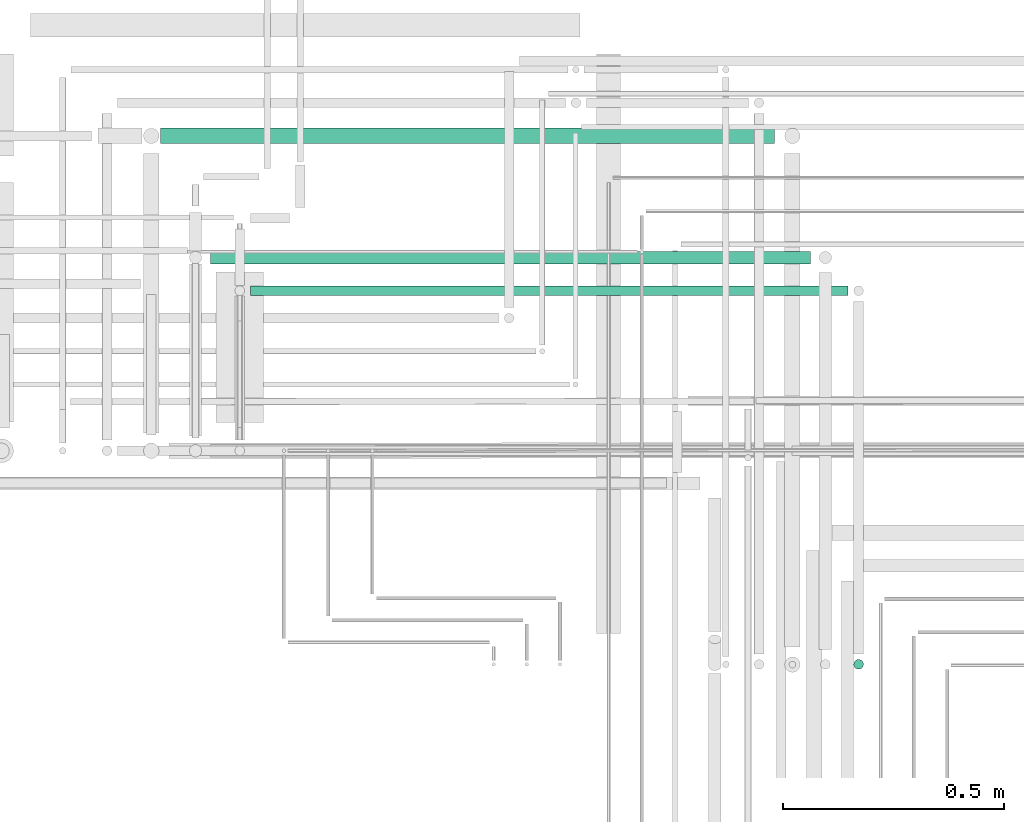
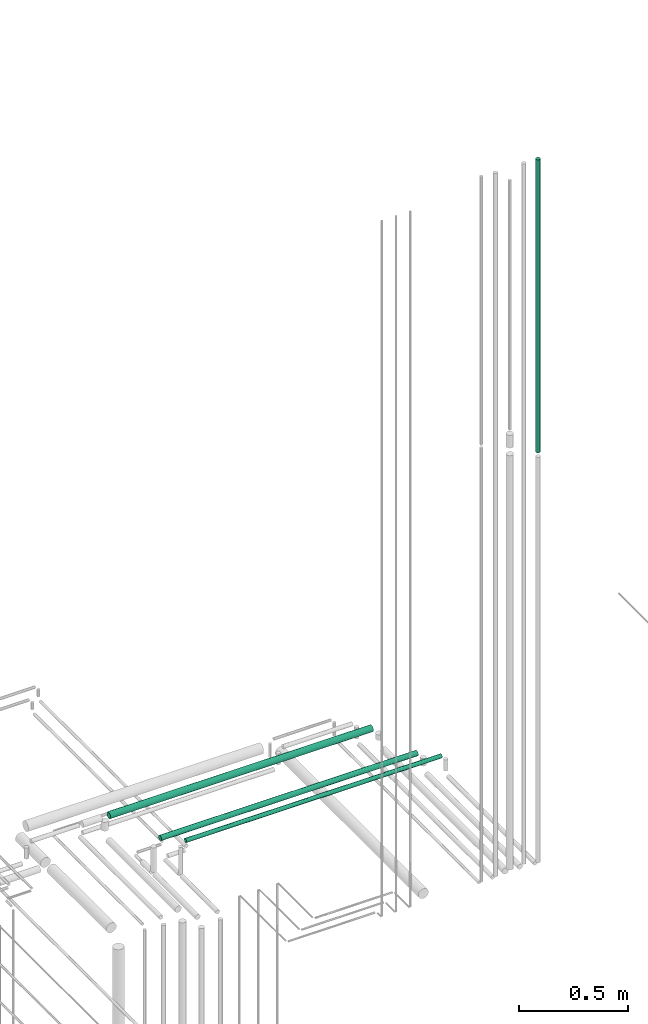
# One storey, part 96 of 331: 4 flow segments.
"""IFC2X3 building model written with IfcOpenShell, lengths in millimetres."""

from ifc_helpers import new_model, entity, si_unit, converted_unit, derived_unit, direction, frame, frame_2d, origin, origin_2d_with_axis, place, context, subcontext, project, spatial, circle, extrude, type_object, element, save


model = new_model("IFC2X3")

# Units and contexts
model_context = context("Model", 3, precision=0.01, world=origin(), true_north=direction((6.12303176911189e-17, 1.0)))
body_context = subcontext(model_context, "Body", "Model", "MODEL_VIEW")
ifc_project = project(units=[si_unit("LENGTHUNIT", "METRE", prefix="MILLI"), si_unit("AREAUNIT", "SQUARE_METRE"), si_unit("VOLUMEUNIT", "CUBIC_METRE"), converted_unit("PLANEANGLEUNIT", "DEGREE", entity("IfcRatioMeasure", 0.0174532925199433), si_unit("PLANEANGLEUNIT", "RADIAN"), dimensions=[0, 0, 0, 0, 0, 0, 0]), si_unit("MASSUNIT", "GRAM", prefix="KILO"), derived_unit("MASSDENSITYUNIT", [(si_unit("MASSUNIT", "GRAM", prefix="KILO"), 1), (si_unit("LENGTHUNIT", "METRE"), -3)]), derived_unit("MOMENTOFINERTIAUNIT", [(si_unit("LENGTHUNIT", "METRE"), 4)]), si_unit("TIMEUNIT", "SECOND"), si_unit("FREQUENCYUNIT", "HERTZ"), si_unit("THERMODYNAMICTEMPERATUREUNIT", "DEGREE_CELSIUS"), derived_unit("THERMALTRANSMITTANCEUNIT", [(si_unit("MASSUNIT", "GRAM", prefix="KILO"), 1), (si_unit("THERMODYNAMICTEMPERATUREUNIT", "KELVIN"), -1), (si_unit("TIMEUNIT", "SECOND"), -3)]), derived_unit("VOLUMETRICFLOWRATEUNIT", [(si_unit("LENGTHUNIT", "METRE"), 3), (si_unit("TIMEUNIT", "SECOND"), -1)]), derived_unit("MASSFLOWRATEUNIT", [(si_unit("MASSUNIT", "GRAM", prefix="KILO"), 1), (si_unit("TIMEUNIT", "SECOND"), -1)]), derived_unit("ROTATIONALFREQUENCYUNIT", [(si_unit("TIMEUNIT", "SECOND"), -1)]), si_unit("ELECTRICCURRENTUNIT", "AMPERE"), si_unit("ELECTRICVOLTAGEUNIT", "VOLT"), si_unit("POWERUNIT", "WATT"), si_unit("FORCEUNIT", "NEWTON", prefix="KILO"), si_unit("ILLUMINANCEUNIT", "LUX"), si_unit("LUMINOUSFLUXUNIT", "LUMEN"), si_unit("LUMINOUSINTENSITYUNIT", "CANDELA"), derived_unit("USERDEFINED", [(si_unit("MASSUNIT", "GRAM", prefix="KILO"), -1), (si_unit("LENGTHUNIT", "METRE"), -2), (si_unit("TIMEUNIT", "SECOND"), 3), (si_unit("LUMINOUSFLUXUNIT", "LUMEN"), 1)]), derived_unit("LINEARVELOCITYUNIT", [(si_unit("LENGTHUNIT", "METRE"), 1), (si_unit("TIMEUNIT", "SECOND"), -1)]), si_unit("PRESSUREUNIT", "PASCAL"), derived_unit("USERDEFINED", [(si_unit("LENGTHUNIT", "METRE"), -2), (si_unit("MASSUNIT", "GRAM", prefix="KILO"), 1), (si_unit("TIMEUNIT", "SECOND"), -2)]), derived_unit("LINEARFORCEUNIT", [(si_unit("MASSUNIT", "GRAM", prefix="KILO"), 1), (si_unit("LENGTHUNIT", "METRE"), 1), (si_unit("TIMEUNIT", "SECOND"), -2), (si_unit("LENGTHUNIT", "METRE"), -1)]), derived_unit("PLANARFORCEUNIT", [(si_unit("MASSUNIT", "GRAM", prefix="KILO"), 1), (si_unit("LENGTHUNIT", "METRE"), 1), (si_unit("TIMEUNIT", "SECOND"), -2), (si_unit("LENGTHUNIT", "METRE"), -2)])], contexts=[model_context])

# Site, building, storey
site_placement = place(None, frame((0.0, -0.00077364408347762, 0.0)))
site = spatial("IfcSite", under=ifc_project, at=site_placement, CompositionType="ELEMENT")
building_placement = place(site_placement, origin())
building = spatial("IfcBuilding", under=site, at=building_placement, CompositionType="ELEMENT")
storey_placement = place(building_placement, origin())
storey = spatial("IfcBuildingStorey", under=building, at=storey_placement, CompositionType="ELEMENT", Elevation=0.0)

# Flow segments
pipe_segment_type = type_object("IfcPipeSegmentType", PredefinedType="NOTDEFINED")
flow_segment_1_placement = place(storey_placement, frame((64072.1118832776, 8840.71546224623, 18540.9047277641)))
element("IfcFlowSegment", 1, at=flow_segment_1_placement, inside=storey, type_object=pipe_segment_type, context=body_context, shape_type="SweptSolid", body=[
    extrude(circle(Radius=17.5, at=origin_2d_with_axis()), frame((0.0, 19.0952722359163, 19.0952722359163), z_axis=(1.0, 0.0, 0.0), x_axis=(0.0, 1.0, 0.0)), (0.0, 0.0, 1.0), 1388.50084826926),
])
flow_segment_2_placement = place(storey_placement, frame((64185.1118832776, 8569.21546224655, 18544.4047277641)))
element("IfcFlowSegment", 2, at=flow_segment_2_placement, inside=storey, type_object=pipe_segment_type, context=body_context, shape_type="SweptSolid", body=[
    extrude(circle(Radius=14.0, at=origin_2d_with_axis()), frame((0.0, 15.595272235916, 15.5952722359149), z_axis=(1.0, 0.0, 0.0), x_axis=(0.0, 1.0, 0.0)), (0.0, 0.0, 1.0), 1356.00000000008),
])
flow_segment_3_placement = place(storey_placement, frame((64275.1118832776, 8497.21546224654, 18547.4047277641)))
element("IfcFlowSegment", 3, at=flow_segment_3_placement, inside=storey, type_object=pipe_segment_type, context=body_context, shape_type="SweptSolid", body=[
    extrude(circle(Radius=11.0, at=frame_2d((6.61415242575458e-09, 0.0), x_axis=(1.0, 0.0))), frame((0.0, 12.5952722425297, 12.5952722359156), z_axis=(1.0, 0.0, 0.0), x_axis=(0.0, 1.0, 0.0)), (0.0, 0.0, 1.0), 1351.00000000007),
])
flow_segment_4_placement = place(building_placement, frame((65637.5166110417, 7652.55397759734, 20762.0)))
element("IfcFlowSegment", 4, at=flow_segment_4_placement, inside=storey, type_object=pipe_segment_type, context=body_context, shape_type="SweptSolid", body=[
    extrude(circle(Radius=11.0, at=origin_2d_with_axis()), frame((12.5952722359134, 12.5952722359156, 0.0)), (0.0, 0.0, 1.0), 1637.00000000002),
])

save(model, "model.ifc")
